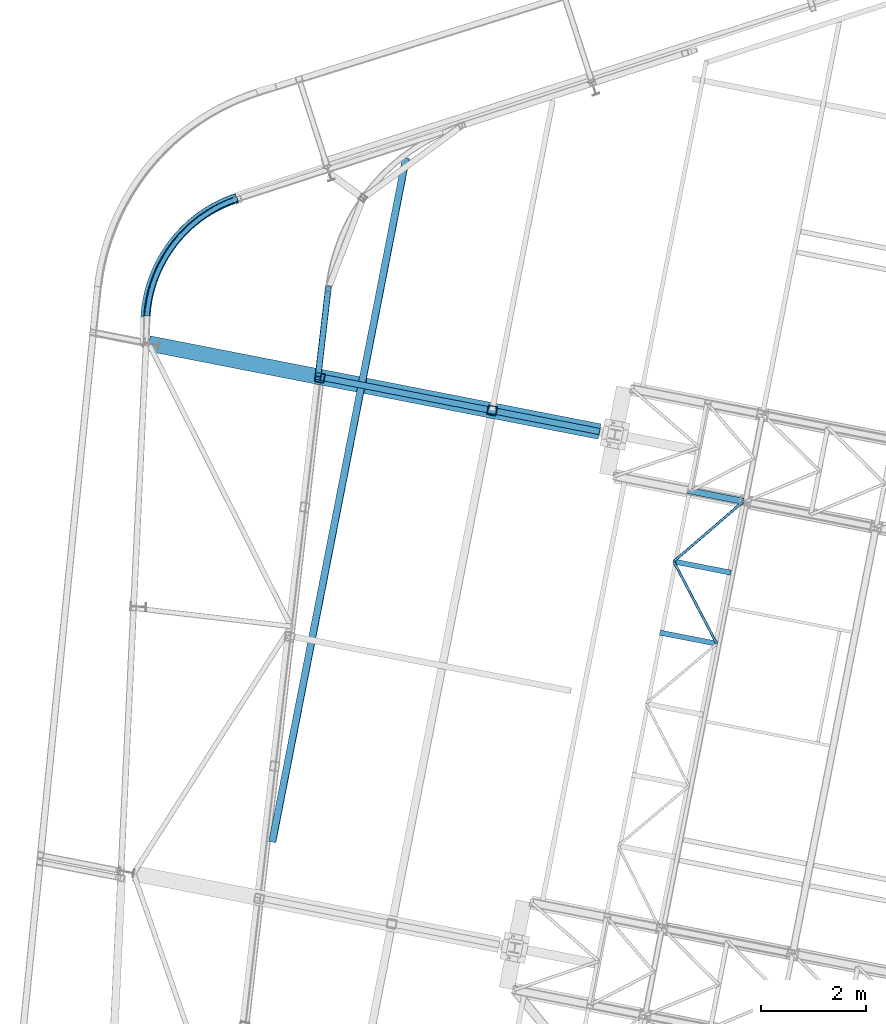
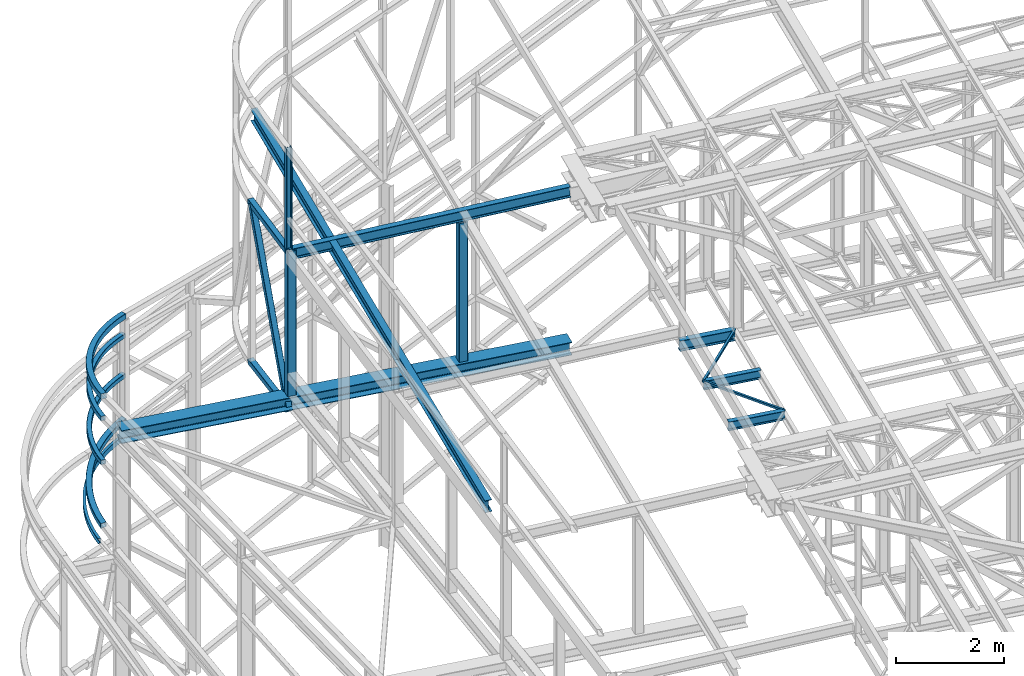
# One storey, part 77 of 215: 18 beams, 1 member, 19 elements without a shape of their own.
"""IFC2X3 building model written with IfcOpenShell, lengths in millimetres."""

import ifcopenshell
import ifcopenshell.guid

model = None  # the IFC model being written
_history = None  # IfcOwnerHistory: only IFC2X3 demands one
_inside = {}  # id of a spatial element -> (the spatial element, [elements in it])
_under = {}  # id of a project, library or spatial element -> (it, [spatial elements below it])
_declared = {}  # id of a project -> (the project, [libraries it declares])
_typed = {}  # id of a type object -> (the type object, [elements of that type])
_made_of = {}  # id of a material, layer set ... -> (it, [elements and type objects made of it])


def new_model(schema):
    """Start an empty IFC model of exactly this schema.

    Asked for "IFC4X3", IfcOpenShell would pick the latest addendum, in which some entities
    have other attributes; the version numbers below select the first issue.
    IFC2X3 requires an IfcOwnerHistory on every rooted entity: one is made here for all.
    """
    global model, _history
    if schema == "IFC4X3":
        model = ifcopenshell.file(schema_version=(4, 3, 0, 0))
    else:
        model = ifcopenshell.file(schema=schema)
    _inside.clear()
    _under.clear()
    _declared.clear()
    _typed.clear()
    _made_of.clear()
    _history = None
    if model.schema == "IFC2X3":
        org = make("IfcOrganization", Name="unknown")
        user = make(
            "IfcPersonAndOrganization",
            ThePerson=make("IfcPerson", FamilyName="unknown"),
            TheOrganization=org,
        )
        app = make(
            "IfcApplication",
            ApplicationDeveloper=org,
            Version="unknown",
            ApplicationFullName="unknown",
            ApplicationIdentifier="unknown",
        )
        _history = make(
            "IfcOwnerHistory",
            OwningUser=user,
            OwningApplication=app,
            ChangeAction="ADDED",
            CreationDate=0,
        )
    return model


def make(cls, **values):
    """One entity of the class cls with the attributes given. An attribute that is None is left unset."""
    return model.create_entity(
        cls, **{name: value for name, value in values.items() if value is not None}
    )


def entity(cls, *values):
    """Any entity or typed value of the class cls, its attributes in the order of the schema. None: left unset."""
    e = model.create_entity(cls)
    for i, value in enumerate(values):
        if value is not None:
            e[i] = value
    return e


def rooted(cls, **values):
    """An entity with a GlobalId (a new one), such as an element, a storey or a relation."""
    return make(cls, GlobalId=ifcopenshell.guid.new(), OwnerHistory=_history, **values)


def si_unit(unit_type, name, prefix=None):
    """IfcSIUnit, for example si_unit("LENGTHUNIT", "METRE", prefix="MILLI")."""
    return make("IfcSIUnit", UnitType=unit_type, Prefix=prefix, Name=name)


def assignment(units):
    """IfcUnitAssignment: the units of a project."""
    return None if units is None else make("IfcUnitAssignment", Units=units)


def point(xyz):
    """IfcCartesianPoint."""
    return None if xyz is None else make("IfcCartesianPoint", Coordinates=xyz)


def direction(xyz):
    """IfcDirection."""
    return None if xyz is None else make("IfcDirection", DirectionRatios=xyz)


def frame(location, z_axis=None, x_axis=None):
    """IfcAxis2Placement3D, a coordinate frame: its origin and axes. An axis left out is left unset."""
    return make(
        "IfcAxis2Placement3D",
        Location=point(location),
        Axis=direction(z_axis),
        RefDirection=direction(x_axis),
    )


def frame_2d(location, x_axis=None):
    """IfcAxis2Placement2D, a coordinate frame in the plane: its origin and x axis."""
    return make(
        "IfcAxis2Placement2D", Location=point(location), RefDirection=direction(x_axis)
    )


def origin_with_axes():
    """The frame at (0, 0, 0) with the z axis (0, 0, 1) and the x axis (1, 0, 0) written out."""
    return frame((0.0, 0.0, 0.0), z_axis=(0.0, 0.0, 1.0), x_axis=(1.0, 0.0, 0.0))


def origin_2d_with_axis():
    """The frame at (0, 0) in the plane with the x axis (1, 0) written out."""
    return frame_2d((0.0, 0.0), x_axis=(1.0, 0.0))


def place(relative_to, where):
    """IfcLocalPlacement: puts the frame where relative to a parent placement (None: the world)."""
    return make(
        "IfcLocalPlacement", PlacementRelTo=relative_to, RelativePlacement=where
    )


def context(
    kind, dimensions, precision=None, world=None, true_north=None, identifier=None
):
    """IfcGeometricRepresentationContext, for example the 3D "Model" context."""
    return make(
        "IfcGeometricRepresentationContext",
        ContextIdentifier=identifier,
        ContextType=kind,
        CoordinateSpaceDimension=dimensions,
        Precision=precision,
        WorldCoordinateSystem=world,
        TrueNorth=true_north,
    )


def subcontext(parent, identifier, kind, view, scale=None):
    """IfcGeometricRepresentationSubContext, for example "Body" below "Model"."""
    return make(
        "IfcGeometricRepresentationSubContext",
        ContextIdentifier=identifier,
        ContextType=kind,
        ParentContext=parent,
        TargetScale=scale,
        TargetView=view,
    )


def project(units=None, contexts=None):
    """IfcProject with its units and contexts."""
    return rooted(
        "IfcProject",
        Name="project",
        RepresentationContexts=contexts,
        UnitsInContext=assignment(units),
    )


def spatial(cls, under=None, at=None, **own):
    """A site, building, storey or space (cls), placed at a placement, below another one or the project."""
    s = rooted(cls, ObjectPlacement=at, **own)
    if under is not None:
        _under.setdefault(under.id(), (under, []))[1].append(s)
    return s


def profile(cls, at=None, kind="AREA", **sizes):
    """A parametric profile (cls). Its sizes go by their IFC names, for example OverallWidth=200.0."""
    return make(cls, ProfileType=kind, Position=at, **sizes)


def hollow_rectangle(**sizes):
    """IfcRectangleHollowProfileDef."""
    return profile("IfcRectangleHollowProfileDef", **sizes)


def i_section(**sizes):
    """IfcIShapeProfileDef."""
    return profile("IfcIShapeProfileDef", **sizes)


def extrude(swept, where, along, depth):
    """IfcExtrudedAreaSolid: the profile swept, set in the frame where, extruded along a direction by depth."""
    return make(
        "IfcExtrudedAreaSolid",
        SweptArea=swept,
        Position=where,
        ExtrudedDirection=direction(along),
        Depth=depth,
    )


def shape(context_of_items, identifier, shape_type, items):
    """IfcShapeRepresentation: the items that make up one representation, for example the "Body"."""
    return make(
        "IfcShapeRepresentation",
        ContextOfItems=context_of_items,
        RepresentationIdentifier=identifier,
        RepresentationType=shape_type,
        Items=items,
    )


def material(Name=None, Category=None):
    """IfcMaterial."""
    return make("IfcMaterial", Name=Name, Category=Category)


def made_of(thing, what):
    """Note that an element or type object is made of a material, layer set ...; save() writes the relation."""
    if what is not None:
        _made_of.setdefault(what.id(), (what, []))[1].append(thing)
    return thing


def type_object(cls, material=None, **own):
    """A type object (cls), such as IfcWallType, which elements share."""
    return made_of(rooted(cls, **own), material)


def element(
    cls,
    number,
    at=None,
    inside=None,
    cuts=None,
    type_object=None,
    material=None,
    context=None,
    identifier="Body",
    shape_type=None,
    held_by="IfcProductDefinitionShape",
    body=None,
    shapes=None,
    **own,
):
    """One element of the class cls, such as IfcWall. Its Tag is "e" and its number.

    at: its placement. inside: the storey or other place that contains it. cuts: it is an
    opening in that element (IfcRelVoidsElement). A single representation is given by context,
    identifier, shape_type and body (its items); several are given by shapes. held_by: the class
    of the entity that holds the representations. save() writes the other relations.
    """
    e = rooted(cls, Tag="e%d" % number, ObjectPlacement=at, **own)
    if body is not None:
        shapes = [shape(context, identifier, shape_type, body)]
    if shapes is not None:
        e.Representation = make(held_by, Representations=shapes)
    if inside is not None:
        _inside.setdefault(inside.id(), (inside, []))[1].append(e)
    if cuts is not None:
        rooted(
            "IfcRelVoidsElement", RelatingBuildingElement=cuts, RelatedOpeningElement=e
        )
    if type_object is not None:
        _typed.setdefault(type_object.id(), (type_object, []))[1].append(e)
    return made_of(e, material)


def aggregate(whole, parts):
    """IfcRelAggregates: a whole, such as a stair, and the parts it consists of."""
    return rooted("IfcRelAggregates", RelatingObject=whole, RelatedObjects=parts)


def save(model, path):
    """Write the relations noted so far, then the file.

    IfcRelAggregates (storeys below a building ...), IfcRelContainedInSpatialStructure (elements
    in a storey), IfcRelDefinesByType, IfcRelAssociatesMaterial and IfcRelDeclares: one each for
    every whole, place, type object, material and project.
    """
    for whole, parts in _under.values():
        aggregate(whole, parts)
    for where, things in _inside.values():
        rooted(
            "IfcRelContainedInSpatialStructure",
            RelatedElements=things,
            RelatingStructure=where,
        )
    for kind, things in _typed.values():
        rooted("IfcRelDefinesByType", RelatedObjects=things, RelatingType=kind)
    for what, things in _made_of.values():
        rooted("IfcRelAssociatesMaterial", RelatedObjects=things, RelatingMaterial=what)
    for by, libraries in _declared.values():
        rooted("IfcRelDeclares", RelatingContext=by, RelatedDefinitions=libraries)
    model.write(path)


model = new_model("IFC2X3")

# Units and contexts
model_context = context("Model", 3, precision=1e-05, world=origin_with_axes())
body_context = subcontext(model_context, "Body", "Model", "MODEL_VIEW")
ifc_project = project(units=[si_unit("LENGTHUNIT", "METRE", prefix="MILLI"), si_unit("AREAUNIT", "SQUARE_METRE"), si_unit("VOLUMEUNIT", "CUBIC_METRE"), si_unit("MASSUNIT", "GRAM", prefix="KILO"), si_unit("TIMEUNIT", "SECOND"), si_unit("PLANEANGLEUNIT", "RADIAN"), si_unit("SOLIDANGLEUNIT", "STERADIAN"), si_unit("THERMODYNAMICTEMPERATUREUNIT", "DEGREE_CELSIUS"), si_unit("LUMINOUSINTENSITYUNIT", "LUMEN")], contexts=[model_context])

# Site, building, storey
site_placement = place(None, origin_with_axes())
site = spatial("IfcSite", under=ifc_project, at=site_placement, CompositionType="ELEMENT")
building_placement = place(site_placement, origin_with_axes())
building = spatial("IfcBuilding", under=site, at=building_placement, Name="Undefined", CompositionType="ELEMENT")
storey_placement = place(building_placement, origin_with_axes())
storey = spatial("IfcBuildingStorey", under=building, at=storey_placement, Name="Undefined", CompositionType="ELEMENT", Elevation=0.0)

# Assembly, beam
assembly_1_placement = place(storey_placement, origin_with_axes())
assembly_1 = element("IfcElementAssembly", 1, at=assembly_1_placement, inside=storey, Name="Steel Assembly", AssemblyPlace="NOTDEFINED", PredefinedType="RIGID_FRAME")
ifc_material_1 = material(Name="STEEL/S275JR")
beam_type_1 = type_object("IfcBeamType", Name="IPE240", PredefinedType="NOTDEFINED")
beam_1_placement = place(assembly_1_placement, frame((42332.7406560366, 53728.3374905815, 11827.4715249186), z_axis=(-0.0304096159955003, 0.00593641699911929, 0.999519891852193), x_axis=(0.98099947062965, -0.191520371927696, 0.0309836369883031)))
beam_1 = element("IfcBeam", 2, at=beam_1_placement, type_object=beam_type_1, material=ifc_material_1, Name="POUTRE", ObjectType="IPE240", context=body_context, shape_type="SweptSolid", body=[
    extrude(i_section(OverallWidth=120.0, OverallDepth=240.0, WebThickness=6.199999809, FlangeThickness=9.800000191, FilletRadius=15.0, at=origin_2d_with_axis()), frame((5486.90339267961, 8.96391998045522e-14, -1.83802592379725e-12), z_axis=(-1.0, 0.0, 0.0), x_axis=(-6.93889390390723e-18, -1.0, -3.46944695195361e-18)), (0.0, 0.0, 1.0), 5486.9),
])
aggregate(assembly_1, [beam_1])

assembly_2_placement = place(storey_placement, origin_with_axes())
assembly_2 = element("IfcElementAssembly", 3, at=assembly_2_placement, inside=storey, Name="Steel Assembly", AssemblyPlace="NOTDEFINED", PredefinedType="RIGID_FRAME")
ifc_material_2 = material(Name="STEEL/S355JR")
beam_2_placement = place(assembly_2_placement, frame((49394.7731976896, 51552.4101806629, 8620.00000002227), z_axis=(0.0, 0.0, 1.0), x_axis=(0.981422409205525, -0.19185946604018, 1.89999991602007e-08)))
beam_2 = element("IfcBeam", 4, at=beam_2_placement, type_object=beam_type_1, material=ifc_material_2, ObjectType="IPE240", context=body_context, shape_type="SweptSolid", body=[
    extrude(i_section(OverallWidth=120.0, OverallDepth=240.0, WebThickness=6.199999809, FlangeThickness=9.800000191, FilletRadius=15.0, at=origin_2d_with_axis()), frame((1088.43650584169, -7.30616779592413e-12, 0.0), z_axis=(-1.0, 0.0, 0.0), x_axis=(-6.93889390390723e-18, -1.0, -3.46944695195361e-18)), (0.0, 0.0, 1.0), 1088.4),
])
aggregate(assembly_2, [beam_2])

assembly_3_placement = place(storey_placement, origin_with_axes())
assembly_3 = element("IfcElementAssembly", 5, at=assembly_3_placement, inside=storey, Name="Steel Assembly", AssemblyPlace="NOTDEFINED", PredefinedType="RIGID_FRAME")
beam_type_2 = type_object("IfcBeamType", Name="IPE270", PredefinedType="NOTDEFINED")
beam_3_placement = place(assembly_3_placement, frame((41456.9329874272, 44829.2783286594, 11838.7446161739), z_axis=(-0.0304080349967745, 0.00594450299936818, 0.999519891893966), x_axis=(0.191859470081235, 0.981422408415534, 0.0)))
beam_3 = element("IfcBeam", 6, at=beam_3_placement, type_object=beam_type_2, material=ifc_material_1, ObjectType="IPE270", context=body_context, shape_type="SweptSolid", body=[
    extrude(i_section(OverallWidth=135.0, OverallDepth=270.0, WebThickness=6.599999905, FlangeThickness=10.19999981, FilletRadius=15.0, at=origin_2d_with_axis()), frame((13327.7793779477, -4.09476788372923e-13, -8.01365644228744e-15), z_axis=(-1.0, 0.0, 0.0), x_axis=(-6.93889390390723e-18, -1.0, -3.46944695195361e-18)), (0.0, 0.0, 1.0), 13327.8),
])
aggregate(assembly_3, [beam_3])

assembly_4_placement = place(storey_placement, origin_with_axes())
assembly_4 = element("IfcElementAssembly", 7, at=assembly_4_placement, inside=storey, Name="Steel Assembly", AssemblyPlace="NOTDEFINED", PredefinedType="RIGID_FRAME")
beam_type_3 = type_object("IfcBeamType", PredefinedType="NOTDEFINED")
beam_4_placement = place(assembly_4_placement, frame((39065.798187464, 54875.3949174436, 9062.92276769175), z_axis=(0.794772404245498, -0.60627441218727, 0.0277157460085609), x_axis=(0.606851583626065, 0.793249554511209, -0.0498628089692749)))
beam_4 = element("IfcBeam", 8, at=beam_4_placement, type_object=beam_type_3, material=ifc_material_1, Name="LISSE", context=body_context, shape_type="SweptSolid", body=[
    entity("IfcRevolvedAreaSolid", entity("IfcRectangleHollowProfileDef", "AREA", None, entity("IfcAxis2Placement2D", entity("IfcCartesianPoint", [0.0, 0.0]), entity("IfcDirection", [1.0, 0.0])), 120.0, 120.0, 4.0, 4.0, 8.0), entity("IfcAxis2Placement3D", entity("IfcCartesianPoint", [2827.39894488217, -1.96190213025566e-14, 8.34853543053386e-12]), entity("IfcDirection", [-0.827821321049945, 3.79783283972965e-18, -0.560991854143288]), entity("IfcDirection", [-6.93889390390723e-18, -1.0, -3.46944695195361e-18])), entity("IfcAxis1Placement", entity("IfcCartesianPoint", [0.0, 2520.0, 0.0]), entity("IfcDirection", [-1.0, 0.0, 0.0])), 1.1911669285878),
])
aggregate(assembly_4, [beam_4])

assembly_5_placement = place(storey_placement, origin_with_axes())
assembly_5 = element("IfcElementAssembly", 9, at=assembly_5_placement, inside=storey, Name="Steel Assembly", AssemblyPlace="NOTDEFINED", PredefinedType="RIGID_FRAME")
ifc_material_3 = material(Name="STEEL/S235JR")
beam_type_4 = type_object("IfcBeamType", PredefinedType="NOTDEFINED")
beam_5_placement = place(assembly_5_placement, frame((39062.5326622398, 54877.2365694546, 6156.92743270905), z_axis=(0.79151334107762, -0.611151871059936, 0.000146274000014066), x_axis=(0.604500138100973, 0.782933737130779, 0.146950149024546)))
beam_5 = element("IfcBeam", 10, at=beam_5_placement, type_object=beam_type_4, material=ifc_material_3, Name="LISSE", context=body_context, shape_type="SweptSolid", body=[
    entity("IfcRevolvedAreaSolid", entity("IfcRectangleHollowProfileDef", "AREA", None, entity("IfcAxis2Placement2D", entity("IfcCartesianPoint", [0.0, 0.0]), entity("IfcDirection", [1.0, 0.0])), 120.0, 120.0, 5.0, 5.0, 10.0), entity("IfcAxis2Placement3D", entity("IfcCartesianPoint", [2856.69219013103, 9.88783837866687e-13, -3.69812317863549e-12]), entity("IfcDirection", [-0.826905447808551, -2.17775809028334e-17, -0.562340982309257]), entity("IfcDirection", [-6.93889390390723e-18, -1.0, -3.46944695195361e-18])), entity("IfcAxis1Placement", entity("IfcCartesianPoint", [0.0, 2540.0, 0.0]), entity("IfcDirection", [-1.0, 0.0, 0.0])), 1.19442819901),
])
aggregate(assembly_5, [beam_5])

assembly_6_placement = place(storey_placement, origin_with_axes())
assembly_6 = element("IfcElementAssembly", 11, at=assembly_6_placement, inside=storey, Name="Steel Assembly", AssemblyPlace="NOTDEFINED", PredefinedType="RIGID_FRAME")
beam_6_placement = place(assembly_6_placement, frame((42531.1906984604, 55459.6900245223, 8292.62353289853), z_axis=(0.993285365315575, -0.115690030036753, 0.0), x_axis=(-0.115660111992266, -0.993028495933615, 0.0227408169984793)))
beam_6 = element("IfcBeam", 12, at=beam_6_placement, type_object=beam_type_4, material=ifc_material_1, Name="LISSE", context=body_context, shape_type="SweptSolid", body=[
    extrude(hollow_rectangle(XDim=120.0, YDim=120.0, WallThickness=5.0, InnerFilletRadius=5.0, OuterFilletRadius=10.0, at=origin_2d_with_axis()), frame((1756.6292211138, 1.81898940354586e-12, -2.30203361751764e-14), z_axis=(-1.0, 0.0, 0.0), x_axis=(-6.93889390390723e-18, -1.0, -3.46944695195361e-18)), (0.0, 0.0, 1.0), 1756.6),
])
aggregate(assembly_6, [beam_6])

assembly_7_placement = place(storey_placement, origin_with_axes())
assembly_7 = element("IfcElementAssembly", 13, at=assembly_7_placement, inside=storey, Name="Steel Assembly", AssemblyPlace="NOTDEFINED", PredefinedType="RIGID_FRAME")
beam_7_placement = place(assembly_7_placement, frame((42531.7149743339, 55464.2046562211, 11886.0030979571), z_axis=(0.993324655321394, -0.115352196037323, 0.0), x_axis=(-0.115352196037321, -0.993324655321395, 0.0)))
beam_7 = element("IfcBeam", 14, at=beam_7_placement, type_object=beam_type_4, material=ifc_material_1, Name="LISSE", context=body_context, shape_type="SweptSolid", body=[
    extrude(hollow_rectangle(XDim=120.0, YDim=120.0, WallThickness=5.0, InnerFilletRadius=5.0, OuterFilletRadius=10.0, at=origin_2d_with_axis()), frame((1736.39226037129, 0.0, 0.0), z_axis=(-1.0, 0.0, 0.0), x_axis=(-6.93889390390723e-18, -1.0, -3.46944695195361e-18)), (0.0, 0.0, 1.0), 1736.4),
])
aggregate(assembly_7, [beam_7])

assembly_8_placement = place(storey_placement, origin_with_axes())
assembly_8 = element("IfcElementAssembly", 15, at=assembly_8_placement, inside=storey, Name="Steel Assembly", AssemblyPlace="NOTDEFINED", PredefinedType="RIGID_FRAME")
beam_type_5 = type_object("IfcBeamType", PredefinedType="NOTDEFINED")
beam_8_placement = place(assembly_8_placement, frame((39057.4878665385, 54881.6673365096, 8562.62084464233), z_axis=(0.791615577891552, -0.610548347916356, -0.0239894079967131), x_axis=(0.609835447991145, 0.791915421988503, -0.0311559109995476)))
beam_8 = element("IfcBeam", 16, at=beam_8_placement, type_object=beam_type_5, material=ifc_material_3, Name="LISSE", context=body_context, shape_type="SweptSolid", body=[
    entity("IfcRevolvedAreaSolid", entity("IfcRectangleHollowProfileDef", "AREA", None, entity("IfcAxis2Placement2D", entity("IfcCartesianPoint", [0.0, 0.0]), entity("IfcDirection", [1.0, 0.0])), 100.0, 100.0, 5.0, 5.0, 10.0), entity("IfcAxis2Placement3D", entity("IfcCartesianPoint", [2837.58057457539, -9.84483527538342e-15, 5.86710615168245e-12]), entity("IfcDirection", [-0.83092238281252, 2.88284112835893e-18, -0.556388347955962]), entity("IfcDirection", [-6.93889390390723e-18, -1.0, -3.46944695195361e-18])), entity("IfcAxis1Placement", entity("IfcCartesianPoint", [0.0, 2550.0, 0.0]), entity("IfcDirection", [-1.0, 0.0, 0.0])), 1.1800657696625),
])
aggregate(assembly_8, [beam_8])

assembly_9_placement = place(storey_placement, origin_with_axes())
assembly_9 = element("IfcElementAssembly", 17, at=assembly_9_placement, inside=storey, Name="Steel Assembly", AssemblyPlace="NOTDEFINED", PredefinedType="RIGID_FRAME")
beam_9_placement = place(assembly_9_placement, frame((39060.8461858113, 54884.014756669, 7572.8874635292), z_axis=(0.792362078316303, -0.610051088243528, 8.11120000322275e-05), x_axis=(0.610051090054294, 0.79236208107052, 2.27200000028575e-06)))
beam_9 = element("IfcBeam", 18, at=beam_9_placement, type_object=beam_type_5, material=ifc_material_3, Name="LISSE", context=body_context, shape_type="SweptSolid", body=[
    entity("IfcRevolvedAreaSolid", entity("IfcRectangleHollowProfileDef", "AREA", None, entity("IfcAxis2Placement2D", entity("IfcCartesianPoint", [0.0, 0.0]), entity("IfcDirection", [1.0, 0.0])), 100.0, 100.0, 5.0, 5.0, 10.0), entity("IfcAxis2Placement3D", entity("IfcCartesianPoint", [2833.7857125807, -9.0950790347718e-13, 6.19551912836152e-12]), entity("IfcDirection", [-0.831420146047178, 3.87332141192118e-21, -0.555644257368768]), entity("IfcDirection", [-6.93889390390723e-18, -1.0, -3.46944695195361e-18])), entity("IfcAxis1Placement", entity("IfcCartesianPoint", [0.0, 2550.0, 0.0]), entity("IfcDirection", [-1.0, 0.0, 0.0])), 1.17827530704825),
])
aggregate(assembly_9, [beam_9])

assembly_10_placement = place(storey_placement, origin_with_axes())
assembly_10 = element("IfcElementAssembly", 19, at=assembly_10_placement, inside=storey, Name="Steel Assembly", AssemblyPlace="NOTDEFINED", PredefinedType="RIGID_FRAME")
beam_type_6 = type_object("IfcBeamType", PredefinedType="NOTDEFINED")
beam_10_placement = place(assembly_10_placement, frame((49129.1598676765, 50193.7374251777, 8715.68808120926), z_axis=(0.0, 0.0, -1.0), x_axis=(0.464072213882643, -0.88579736977599, 0.0)))
beam_10 = element("IfcBeam", 20, at=beam_10_placement, type_object=beam_type_6, material=ifc_material_1, context=body_context, shape_type="SweptSolid", body=[
    extrude(hollow_rectangle(XDim=50.0, YDim=50.0, WallThickness=3.0, InnerFilletRadius=3.0, OuterFilletRadius=6.0, at=origin_2d_with_axis()), frame((1773.79471437016, 0.0, 0.0), z_axis=(-1.0, 0.0, 0.0), x_axis=(-6.93889390390723e-18, -1.0, -3.46944695195361e-18)), (0.0, 0.0, 1.0), 1773.8),
])
aggregate(assembly_10, [beam_10])

assembly_11_placement = place(storey_placement, origin_with_axes())
assembly_11 = element("IfcElementAssembly", 21, at=assembly_11_placement, inside=storey, Name="Steel Assembly", AssemblyPlace="NOTDEFINED", PredefinedType="RIGID_FRAME")
beam_11_placement = place(assembly_11_placement, frame((50462.9891791419, 51343.5833500399, 8715.6880812093), z_axis=(0.0, 0.0, -1.0), x_axis=(-0.757411908118356, -0.652937364102033, 0.0)))
beam_11 = element("IfcBeam", 22, at=beam_11_placement, type_object=beam_type_6, material=ifc_material_1, context=body_context, shape_type="SweptSolid", body=[
    extrude(hollow_rectangle(XDim=50.0, YDim=50.0, WallThickness=3.0, InnerFilletRadius=3.0, OuterFilletRadius=6.0, at=origin_2d_with_axis()), frame((1761.03557128562, -9.77571119212604e-14, 0.0), z_axis=(-1.0, 0.0, 0.0), x_axis=(-6.93889390390723e-18, -1.0, -3.46944695195361e-18)), (0.0, 0.0, 1.0), 1761.0),
])
aggregate(assembly_11, [beam_11])

# Assembly, member
assembly_12_placement = place(storey_placement, origin_with_axes())
assembly_12 = element("IfcElementAssembly", 23, at=assembly_12_placement, inside=storey, Name="Steel Assembly", AssemblyPlace="NOTDEFINED", PredefinedType="RIGID_FRAME")
member_type = type_object("IfcMemberType", PredefinedType="NOTDEFINED")
member_placement = place(assembly_12_placement, frame((42524.8147071562, 55404.7848466333, 11885.8222207942), z_axis=(0.104002318028175, 0.895588211242635, -0.432556671117189), x_axis=(-0.0498963620059516, -0.429669206051254, -0.901606747107549)))
member = element("IfcMember", 24, at=member_placement, type_object=member_type, material=ifc_material_1, context=body_context, shape_type="SweptSolid", body=[
    extrude(hollow_rectangle(XDim=120.0, YDim=120.0, WallThickness=5.0, InnerFilletRadius=5.0, OuterFilletRadius=10.0, at=origin_2d_with_axis()), frame((3911.46543507339, -3.91695674358881e-15, -2.17129949302197e-13), z_axis=(-1.0, 0.0, 0.0), x_axis=(-6.93889390390723e-18, -1.0, -3.46944695195361e-18)), (0.0, 0.0, 1.0), 3911.5),
])
aggregate(assembly_12, [member])

# Assembly, beam
assembly_13_placement = place(storey_placement, origin_with_axes())
assembly_13 = element("IfcElementAssembly", 25, at=assembly_13_placement, inside=storey, Name="Steel Assembly", AssemblyPlace="NOTDEFINED", PredefinedType="RIGID_FRAME")
beam_type_7 = type_object("IfcBeamType", PredefinedType="NOTDEFINED")
beam_12_placement = place(assembly_13_placement, frame((42364.5449442647, 53706.3365385918, 11935.7585142035), z_axis=(-0.981475092367809, 0.1915897780718, 0.0), x_axis=(0.0, 0.0, -1.0)))
beam_12 = element("IfcBeam", 26, at=beam_12_placement, type_object=beam_type_7, material=ifc_material_1, Name="MONTANT", context=body_context, shape_type="SweptSolid", body=[
    extrude(hollow_rectangle(XDim=180.0, YDim=180.0, WallThickness=8.0, InnerFilletRadius=12.0, OuterFilletRadius=20.0, at=origin_2d_with_axis()), frame((3256.46645865621, 0.0, 0.0), z_axis=(-1.0, 0.0, 0.0), x_axis=(-6.93889390390723e-18, -1.0, -3.46944695195361e-18)), (0.0, 0.0, 1.0), 3256.5),
])
aggregate(assembly_13, [beam_12])

assembly_14_placement = place(storey_placement, origin_with_axes())
assembly_14 = element("IfcElementAssembly", 27, at=assembly_14_placement, inside=storey, Name="Steel Assembly", AssemblyPlace="NOTDEFINED", PredefinedType="RIGID_FRAME")
beam_13_placement = place(assembly_14_placement, frame((45657.0813119399, 53079.2039472835, 11804.5925857913), z_axis=(-0.981422412140383, 0.191859451027444, 0.0), x_axis=(0.0, 0.0, -1.0)))
beam_13 = element("IfcBeam", 28, at=beam_13_placement, type_object=beam_type_7, material=ifc_material_1, Name="MONTANT", context=body_context, shape_type="SweptSolid", body=[
    extrude(hollow_rectangle(XDim=180.0, YDim=180.0, WallThickness=8.0, InnerFilletRadius=12.0, OuterFilletRadius=20.0, at=origin_2d_with_axis()), frame((3125.30053024371, 0.0, 0.0), z_axis=(-1.0, 0.0, 0.0), x_axis=(-6.93889390390723e-18, -1.0, -3.46944695195361e-18)), (0.0, 0.0, 1.0), 3125.3),
])
aggregate(assembly_14, [beam_13])

assembly_15_placement = place(storey_placement, origin_with_axes())
assembly_15 = element("IfcElementAssembly", 29, at=assembly_15_placement, inside=storey, Name="Steel Assembly", AssemblyPlace="NOTDEFINED", PredefinedType="RIGID_FRAME")
beam_type_8 = type_object("IfcBeamType", Name="HEA120", PredefinedType="NOTDEFINED")
beam_14_placement = place(assembly_15_placement, frame((42330.8536948596, 53728.6900959079, 14219.9969936295), z_axis=(0.981422409205525, -0.19185946604018, 1.89999991602007e-08), x_axis=(0.0, 0.0, -1.0)))
beam_14 = element("IfcBeam", 30, at=beam_14_placement, type_object=beam_type_8, material=ifc_material_1, ObjectType="HEA120", context=body_context, shape_type="SweptSolid", body=[
    extrude(i_section(OverallWidth=120.0, OverallDepth=114.0, WebThickness=5.0, FlangeThickness=8.0, FilletRadius=12.0, at=origin_2d_with_axis()), frame((2273.4130999881, -3.76104648126847e-21, -3.63797881461381e-12), z_axis=(-1.0, 0.0, 0.0), x_axis=(-6.93889390390723e-18, -1.0, -3.46944695195361e-18)), (0.0, 0.0, 1.0), 2273.4),
])
aggregate(assembly_15, [beam_14])

assembly_16_placement = place(storey_placement, origin_with_axes())
assembly_16 = element("IfcElementAssembly", 31, at=assembly_16_placement, inside=storey, Name="Steel Assembly", AssemblyPlace="NOTDEFINED", PredefinedType="RIGID_FRAME")
beam_type_9 = type_object("IfcBeamType", Name="UPN120", PredefinedType="NOTDEFINED")
beam_15_placement = place(assembly_16_placement, frame((38971.3348000427, 54872.2694974405, 5836.2010521585), z_axis=(0.0513459970115321, 0.067190343015097, -0.996418108223855), x_axis=(0.605014873138631, 0.791710837181409, 0.0845633110193764)))
beam_15 = element("IfcBeam", 32, at=beam_15_placement, type_object=beam_type_9, material=ifc_material_3, Name="LISSE", ObjectType="UPN120", context=body_context, shape_type="SweptSolid", body=[
    entity("IfcRevolvedAreaSolid", entity("IfcUShapeProfileDef", "AREA", None, entity("IfcAxis2Placement2D", entity("IfcCartesianPoint", [0.0, 0.0]), entity("IfcDirection", [1.0, 0.0])), 120.0, 55.0, 7.0, 9.0, 9.0, 4.5, 0.0798299857122373), entity("IfcAxis2Placement3D", entity("IfcCartesianPoint", [2941.46085694419, -4.73547293140788e-13, -2.8421709430404e-14]), entity("IfcDirection", [-0.828664797787072, -0.559745167829532, 3.3243606095349e-18]), entity("IfcDirection", [0.559745167829532, -0.828664797787072, 4.92149065431594e-18])), entity("IfcAxis1Placement", entity("IfcCartesianPoint", [-2627.5, 0.0, 0.0]), entity("IfcDirection", [-6.93889390390723e-18, -1.0, -3.46944695195361e-18])), 1.18815649327126),
])
aggregate(assembly_16, [beam_15])

assembly_17_placement = place(storey_placement, origin_with_axes())
assembly_17 = element("IfcElementAssembly", 33, at=assembly_17_placement, inside=storey, Name="Steel Assembly", AssemblyPlace="NOTDEFINED", PredefinedType="RIGID_FRAME")
beam_type_10 = type_object("IfcBeamType", Name="IPE200", PredefinedType="NOTDEFINED")
beam_16_placement = place(assembly_17_placement, frame((50217.9374592684, 49981.1883831606, 8640.68808121306), z_axis=(0.0, 0.0, -1.0), x_axis=(-0.98147285858664, 0.191601220919307, 0.0)))
beam_16 = element("IfcBeam", 34, at=beam_16_placement, type_object=beam_type_10, material=ifc_material_1, ObjectType="IPE200", context=body_context, shape_type="SweptSolid", body=[
    extrude(i_section(OverallWidth=100.0, OverallDepth=200.0, WebThickness=5.599999905, FlangeThickness=8.5, FilletRadius=12.0, at=origin_2d_with_axis()), frame((1109.33031115782, 0.0, 0.0), z_axis=(-1.0, 0.0, 0.0), x_axis=(-6.93889390390723e-18, -1.0, -3.46944695195361e-18)), (0.0, 0.0, 1.0), 1109.3),
])
aggregate(assembly_17, [beam_16])

assembly_18_placement = place(storey_placement, origin_with_axes())
assembly_18 = element("IfcElementAssembly", 35, at=assembly_18_placement, inside=storey, Name="Steel Assembly", AssemblyPlace="NOTDEFINED", PredefinedType="RIGID_FRAME")
beam_17_placement = place(assembly_18_placement, frame((49952.3287086257, 48622.5147324992, 8640.6880812167), z_axis=(0.0, 0.0, -1.0), x_axis=(-0.98147285858664, 0.191601220919307, 0.0)))
beam_17 = element("IfcBeam", 36, at=beam_17_placement, type_object=beam_type_10, material=ifc_material_1, ObjectType="IPE200", context=body_context, shape_type="SweptSolid", body=[
    extrude(i_section(OverallWidth=100.0, OverallDepth=200.0, WebThickness=5.599999905, FlangeThickness=8.5, FilletRadius=12.0, at=origin_2d_with_axis()), frame((1109.33031115782, 0.0, 0.0), z_axis=(-1.0, 0.0, 0.0), x_axis=(-6.93889390390723e-18, -1.0, -3.46944695195361e-18)), (0.0, 0.0, 1.0), 1109.3),
])
aggregate(assembly_18, [beam_17])

assembly_19_placement = place(storey_placement, origin_with_axes())
assembly_19 = element("IfcElementAssembly", 37, at=assembly_19_placement, inside=storey, Name="Steel Assembly", AssemblyPlace="NOTDEFINED", PredefinedType="RIGID_FRAME")
beam_type_11 = type_object("IfcBeamType", Name="HEA300", PredefinedType="NOTDEFINED")
beam_18_placement = place(assembly_19_placement, frame((39093.9478274879, 54360.7504437694, 8534.29205574912), z_axis=(0.0, 0.0, 1.0), x_axis=(0.981468455340895, -0.191623775066557, 0.0)))
beam_18 = element("IfcBeam", 38, at=beam_18_placement, type_object=beam_type_11, material=ifc_material_1, Name="POUTRE", ObjectType="HEA300", context=body_context, shape_type="SweptSolid", body=[
    extrude(i_section(OverallWidth=300.0, OverallDepth=290.0, WebThickness=8.5, FlangeThickness=14.0, FilletRadius=27.0, at=origin_2d_with_axis()), frame((8780.5244373417, 0.0, -1.81898940354586e-12), z_axis=(-1.0, 0.0, 0.0), x_axis=(-6.93889390390723e-18, -1.0, -3.46944695195361e-18)), (0.0, 0.0, 1.0), 8780.5),
])
aggregate(assembly_19, [beam_18])

save(model, "model.ifc")
